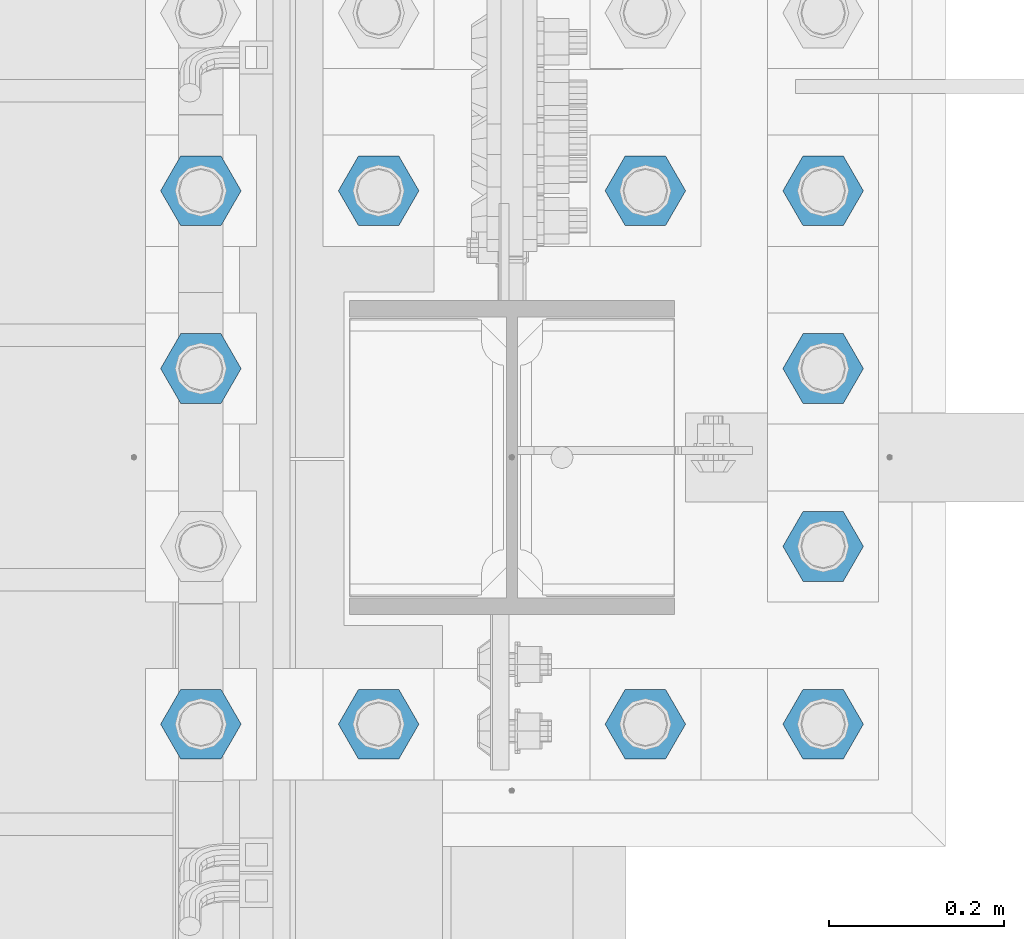
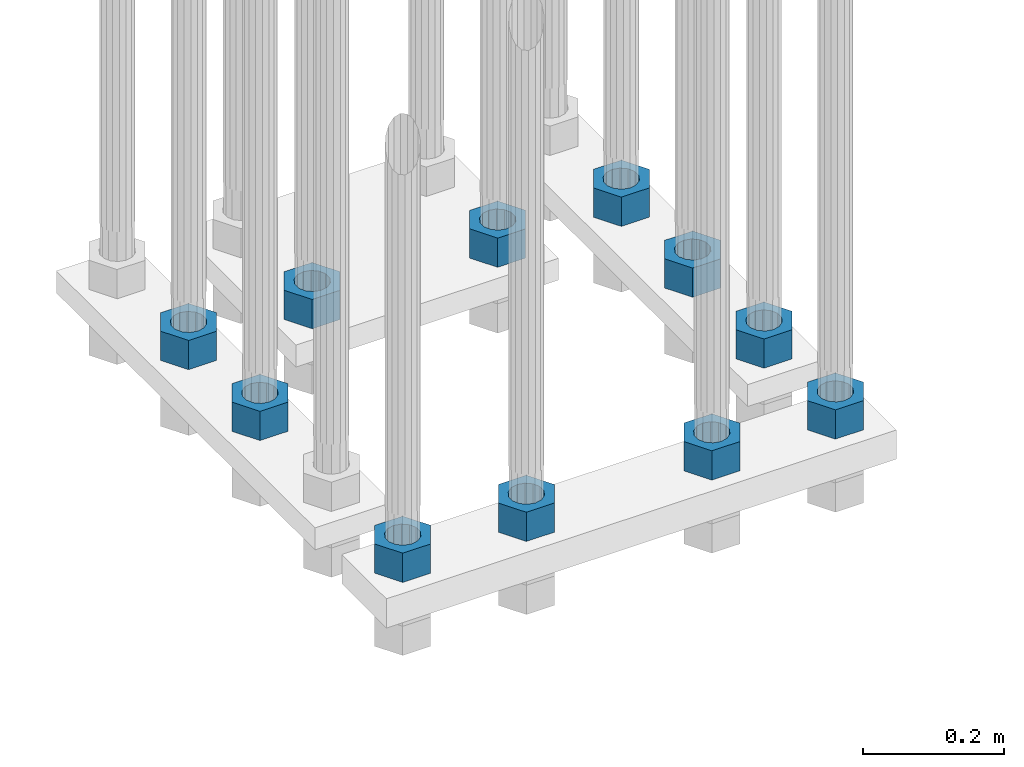
# One storey, part 2089 of 3843: 11 beams, 1 element without a shape of its own.
"""IFC2X3 building model written with IfcOpenShell, lengths in millimetres."""

import ifcopenshell
import ifcopenshell.guid

model = None  # the IFC model being written
_history = None  # IfcOwnerHistory: only IFC2X3 demands one
_inside = {}  # id of a spatial element -> (the spatial element, [elements in it])
_under = {}  # id of a project, library or spatial element -> (it, [spatial elements below it])
_declared = {}  # id of a project -> (the project, [libraries it declares])
_typed = {}  # id of a type object -> (the type object, [elements of that type])
_made_of = {}  # id of a material, layer set ... -> (it, [elements and type objects made of it])


def new_model(schema):
    """Start an empty IFC model of exactly this schema.

    Asked for "IFC4X3", IfcOpenShell would pick the latest addendum, in which some entities
    have other attributes; the version numbers below select the first issue.
    IFC2X3 requires an IfcOwnerHistory on every rooted entity: one is made here for all.
    """
    global model, _history
    if schema == "IFC4X3":
        model = ifcopenshell.file(schema_version=(4, 3, 0, 0))
    else:
        model = ifcopenshell.file(schema=schema)
    _inside.clear()
    _under.clear()
    _declared.clear()
    _typed.clear()
    _made_of.clear()
    _history = None
    if model.schema == "IFC2X3":
        org = make("IfcOrganization", Name="unknown")
        user = make(
            "IfcPersonAndOrganization",
            ThePerson=make("IfcPerson", FamilyName="unknown"),
            TheOrganization=org,
        )
        app = make(
            "IfcApplication",
            ApplicationDeveloper=org,
            Version="unknown",
            ApplicationFullName="unknown",
            ApplicationIdentifier="unknown",
        )
        _history = make(
            "IfcOwnerHistory",
            OwningUser=user,
            OwningApplication=app,
            ChangeAction="ADDED",
            CreationDate=0,
        )
    return model


def make(cls, **values):
    """One entity of the class cls with the attributes given. An attribute that is None is left unset."""
    return model.create_entity(
        cls, **{name: value for name, value in values.items() if value is not None}
    )


def rooted(cls, **values):
    """An entity with a GlobalId (a new one), such as an element, a storey or a relation."""
    return make(cls, GlobalId=ifcopenshell.guid.new(), OwnerHistory=_history, **values)


def si_unit(unit_type, name, prefix=None):
    """IfcSIUnit, for example si_unit("LENGTHUNIT", "METRE", prefix="MILLI")."""
    return make("IfcSIUnit", UnitType=unit_type, Prefix=prefix, Name=name)


def assignment(units):
    """IfcUnitAssignment: the units of a project."""
    return None if units is None else make("IfcUnitAssignment", Units=units)


def point(xyz):
    """IfcCartesianPoint."""
    return None if xyz is None else make("IfcCartesianPoint", Coordinates=xyz)


def direction(xyz):
    """IfcDirection."""
    return None if xyz is None else make("IfcDirection", DirectionRatios=xyz)


def frame(location, z_axis=None, x_axis=None):
    """IfcAxis2Placement3D, a coordinate frame: its origin and axes. An axis left out is left unset."""
    return make(
        "IfcAxis2Placement3D",
        Location=point(location),
        Axis=direction(z_axis),
        RefDirection=direction(x_axis),
    )


def origin_with_axes():
    """The frame at (0, 0, 0) with the z axis (0, 0, 1) and the x axis (1, 0, 0) written out."""
    return frame((0.0, 0.0, 0.0), z_axis=(0.0, 0.0, 1.0), x_axis=(1.0, 0.0, 0.0))


def place(relative_to, where):
    """IfcLocalPlacement: puts the frame where relative to a parent placement (None: the world)."""
    return make(
        "IfcLocalPlacement", PlacementRelTo=relative_to, RelativePlacement=where
    )


def context(
    kind, dimensions, precision=None, world=None, true_north=None, identifier=None
):
    """IfcGeometricRepresentationContext, for example the 3D "Model" context."""
    return make(
        "IfcGeometricRepresentationContext",
        ContextIdentifier=identifier,
        ContextType=kind,
        CoordinateSpaceDimension=dimensions,
        Precision=precision,
        WorldCoordinateSystem=world,
        TrueNorth=true_north,
    )


def subcontext(parent, identifier, kind, view, scale=None):
    """IfcGeometricRepresentationSubContext, for example "Body" below "Model"."""
    return make(
        "IfcGeometricRepresentationSubContext",
        ContextIdentifier=identifier,
        ContextType=kind,
        ParentContext=parent,
        TargetScale=scale,
        TargetView=view,
    )


def project(units=None, contexts=None):
    """IfcProject with its units and contexts."""
    return rooted(
        "IfcProject",
        Name="project",
        RepresentationContexts=contexts,
        UnitsInContext=assignment(units),
    )


def spatial(cls, under=None, at=None, **own):
    """A site, building, storey or space (cls), placed at a placement, below another one or the project."""
    s = rooted(cls, ObjectPlacement=at, **own)
    if under is not None:
        _under.setdefault(under.id(), (under, []))[1].append(s)
    return s


def faces_of(points, faces, orient=None, outer=None):
    """IfcFace entities. A face is a list of loops; a loop is a list of indices into points, from 0.

    orient and outer hold one flag for each loop. By default every Orientation is true, the
    first loop of a face is its IfcFaceOuterBound and the others are IfcFaceBound.
    """
    made = []
    for i, loops in enumerate(faces):
        bounds = []
        for j, loop in enumerate(loops):
            is_outer = j == 0 if outer is None else outer[i][j]
            bounds.append(
                make(
                    "IfcFaceOuterBound" if is_outer else "IfcFaceBound",
                    Bound=make("IfcPolyLoop", Polygon=[points[k] for k in loop]),
                    Orientation=True if orient is None else orient[i][j],
                )
            )
        made.append(make("IfcFace", Bounds=bounds))
    return made


def faceted_brep(points, faces, orient=None, outer=None, voids=None):
    """IfcFacetedBrep: a solid bounded by flat faces; with voids (closed shells), ...WithVoids."""
    shared = [point(p) for p in points]
    hull = make("IfcClosedShell", CfsFaces=faces_of(shared, faces, orient, outer))
    if voids is None:
        return make("IfcFacetedBrep", Outer=hull)
    return make(
        "IfcFacetedBrepWithVoids",
        Outer=hull,
        Voids=[
            make(cls, CfsFaces=faces_of(shared, fs, o, b)) for cls, fs, o, b in voids
        ],
    )


def shape(context_of_items, identifier, shape_type, items):
    """IfcShapeRepresentation: the items that make up one representation, for example the "Body"."""
    return make(
        "IfcShapeRepresentation",
        ContextOfItems=context_of_items,
        RepresentationIdentifier=identifier,
        RepresentationType=shape_type,
        Items=items,
    )


def material(Name=None, Category=None):
    """IfcMaterial."""
    return make("IfcMaterial", Name=Name, Category=Category)


def made_of(thing, what):
    """Note that an element or type object is made of a material, layer set ...; save() writes the relation."""
    if what is not None:
        _made_of.setdefault(what.id(), (what, []))[1].append(thing)
    return thing


def type_object(cls, material=None, **own):
    """A type object (cls), such as IfcWallType, which elements share."""
    return made_of(rooted(cls, **own), material)


def element(
    cls,
    number,
    at=None,
    inside=None,
    cuts=None,
    type_object=None,
    material=None,
    context=None,
    identifier="Body",
    shape_type=None,
    held_by="IfcProductDefinitionShape",
    body=None,
    shapes=None,
    **own,
):
    """One element of the class cls, such as IfcWall. Its Tag is "e" and its number.

    at: its placement. inside: the storey or other place that contains it. cuts: it is an
    opening in that element (IfcRelVoidsElement). A single representation is given by context,
    identifier, shape_type and body (its items); several are given by shapes. held_by: the class
    of the entity that holds the representations. save() writes the other relations.
    """
    e = rooted(cls, Tag="e%d" % number, ObjectPlacement=at, **own)
    if body is not None:
        shapes = [shape(context, identifier, shape_type, body)]
    if shapes is not None:
        e.Representation = make(held_by, Representations=shapes)
    if inside is not None:
        _inside.setdefault(inside.id(), (inside, []))[1].append(e)
    if cuts is not None:
        rooted(
            "IfcRelVoidsElement", RelatingBuildingElement=cuts, RelatedOpeningElement=e
        )
    if type_object is not None:
        _typed.setdefault(type_object.id(), (type_object, []))[1].append(e)
    return made_of(e, material)


def aggregate(whole, parts):
    """IfcRelAggregates: a whole, such as a stair, and the parts it consists of."""
    return rooted("IfcRelAggregates", RelatingObject=whole, RelatedObjects=parts)


def save(model, path):
    """Write the relations noted so far, then the file.

    IfcRelAggregates (storeys below a building ...), IfcRelContainedInSpatialStructure (elements
    in a storey), IfcRelDefinesByType, IfcRelAssociatesMaterial and IfcRelDeclares: one each for
    every whole, place, type object, material and project.
    """
    for whole, parts in _under.values():
        aggregate(whole, parts)
    for where, things in _inside.values():
        rooted(
            "IfcRelContainedInSpatialStructure",
            RelatedElements=things,
            RelatingStructure=where,
        )
    for kind, things in _typed.values():
        rooted("IfcRelDefinesByType", RelatedObjects=things, RelatingType=kind)
    for what, things in _made_of.values():
        rooted("IfcRelAssociatesMaterial", RelatedObjects=things, RelatingMaterial=what)
    for by, libraries in _declared.values():
        rooted("IfcRelDeclares", RelatingContext=by, RelatedDefinitions=libraries)
    model.write(path)


model = new_model("IFC2X3")

# Units and contexts
model_context = context("Model", 3, precision=1e-05, world=origin_with_axes())
body_context = subcontext(model_context, "Body", "Model", "MODEL_VIEW")
ifc_project = project(units=[si_unit("LENGTHUNIT", "METRE", prefix="MILLI"), si_unit("AREAUNIT", "SQUARE_METRE"), si_unit("VOLUMEUNIT", "CUBIC_METRE"), si_unit("MASSUNIT", "GRAM", prefix="KILO"), si_unit("TIMEUNIT", "SECOND"), si_unit("PLANEANGLEUNIT", "RADIAN"), si_unit("SOLIDANGLEUNIT", "STERADIAN"), si_unit("THERMODYNAMICTEMPERATUREUNIT", "DEGREE_CELSIUS"), si_unit("LUMINOUSINTENSITYUNIT", "LUMEN")], contexts=[model_context])

# Site, building, storey
site_placement = place(None, origin_with_axes())
site = spatial("IfcSite", under=ifc_project, at=site_placement, CompositionType="ELEMENT")
building_placement = place(site_placement, origin_with_axes())
building = spatial("IfcBuilding", under=site, at=building_placement, Name="Undefined", CompositionType="ELEMENT")
storey_placement = place(building_placement, origin_with_axes())
storey = spatial("IfcBuildingStorey", under=building, at=storey_placement, Name="Undefined", CompositionType="ELEMENT", Elevation=0.0)

# Assembly, beams
assembly_placement = place(storey_placement, origin_with_axes())
assembly = element("IfcElementAssembly", 1, at=assembly_placement, inside=storey, Name="TEMPLATE", AssemblyPlace="NOTDEFINED", PredefinedType="RIGID_FRAME")
ifc_material = material(Name="STEEL/A572-50")
beam_type = type_object("IfcBeamType", Name="2_HEAVY_HEX_NUT", PredefinedType="NOTDEFINED")
beam_1_placement = place(assembly_placement, frame((55575.2, 20408.9, 28701.9999969482), z_axis=(0.0, -1.0, 0.0), x_axis=(0.0, 0.0, -1.0)))
beam_1 = element("IfcBeam", 2, at=beam_1_placement, type_object=beam_type, material=ifc_material, Name="NUT", ObjectType="2_HEAVY_HEX_NUT", context=body_context, shape_type="Brep", body=[
    faceted_brep([(0.0, -46.0369987487793, 0.0), (0.0, -23.0184993743896, -39.869213104248), (50.7999999999993, -23.0184993743896, -39.869213104248), (50.7999999999993, -46.0369987487793, 0.0), (0.0, 23.0184993743896, -39.869213104248), (50.7999999999993, 23.0184993743896, -39.869213104248), (0.0, 46.0369987487793, 0.0), (50.7999999999993, 46.0369987487793, 0.0), (0.0, 23.0184993743896, 39.869213104248), (50.7999999999993, 23.0184993743896, 39.869213104248), (0.0, -23.0184993743896, 39.869213104248), (50.7999999999993, -23.0184993743896, 39.869213104248), (0.0, 0.0, 26.1940002441406), (0.0, 11.3650617044477, 23.5999013092805), (50.7999999999993, 11.3650617044477, 23.5999013092805), (50.7999999999993, 0.0, 26.1940002441406), (0.0, 20.4791109456419, 16.3316083006721), (50.7999999999993, 20.4791109456419, 16.3316083006721), (0.0, 25.5370200498292, 5.82867859874386), (50.7999999999993, 25.5370200498292, 5.82867859874386), (0.0, 25.5370200498292, -5.82867859874386), (50.7999999999993, 25.5370200498292, -5.82867859874386), (0.0, 20.4791109456419, -16.3316083006721), (50.7999999999993, 20.4791109456419, -16.3316083006721), (0.0, 11.3650617044477, -23.5999013092805), (50.7999999999993, 11.3650617044477, -23.5999013092805), (0.0, 0.0, -26.1940002441406), (50.7999999999993, 0.0, -26.1940002441406), (0.0, -11.3650617044477, -23.5999013092805), (50.7999999999993, -11.3650617044477, -23.5999013092805), (0.0, -20.4791109456419, -16.3316083006721), (50.7999999999993, -20.4791109456419, -16.3316083006721), (0.0, -25.5370200498292, -5.82867859874386), (50.7999999999993, -25.5370200498292, -5.82867859874386), (0.0, -25.5370200498292, 5.82867859874386), (50.7999999999993, -25.5370200498292, 5.82867859874386), (0.0, -20.4791109456419, 16.3316083006721), (50.7999999999993, -20.4791109456419, 16.3316083006721), (0.0, -11.3650617044477, 23.5999013092805), (50.7999999999993, -11.3650617044477, 23.5999013092805)], [[[0, 1, 2, 3]], [[1, 4, 5, 2]], [[4, 6, 7, 5]], [[6, 8, 9, 7]], [[8, 10, 11, 9]], [[10, 0, 3, 11]], [[12, 13, 14, 15]], [[13, 16, 17, 14]], [[16, 18, 19, 17]], [[18, 20, 21, 19]], [[20, 22, 23, 21]], [[22, 24, 25, 23]], [[24, 26, 27, 25]], [[26, 28, 29, 27]], [[28, 30, 31, 29]], [[30, 32, 33, 31]], [[32, 34, 35, 33]], [[34, 36, 37, 35]], [[36, 38, 39, 37]], [[38, 12, 15, 39]], [[5, 7, 9, 11, 3, 2], [17, 19, 21, 23, 25, 27, 29, 31, 33, 35, 37, 39, 15, 14]], [[10, 8, 6, 4, 1, 0], [38, 36, 34, 32, 30, 28, 26, 24, 22, 20, 18, 16, 13, 12]]]),
])
beam_2_placement = place(assembly_placement, frame((55575.2, 20612.1, 28701.9999969482), z_axis=(0.0, -1.0, 0.0), x_axis=(0.0, 0.0, -1.0)))
beam_2 = element("IfcBeam", 3, at=beam_2_placement, type_object=beam_type, material=ifc_material, Name="NUT", ObjectType="2_HEAVY_HEX_NUT", context=body_context, shape_type="Brep", body=[
    faceted_brep([(0.0, -46.0369987487793, 0.0), (0.0, -23.0184993743896, -39.869213104248), (50.7999999999993, -23.0184993743896, -39.869213104248), (50.7999999999993, -46.0369987487793, 0.0), (0.0, 23.0184993743896, -39.869213104248), (50.7999999999993, 23.0184993743896, -39.869213104248), (0.0, 46.0369987487793, 0.0), (50.7999999999993, 46.0369987487793, 0.0), (0.0, 23.0184993743896, 39.869213104248), (50.7999999999993, 23.0184993743896, 39.869213104248), (0.0, -23.0184993743896, 39.869213104248), (50.7999999999993, -23.0184993743896, 39.869213104248), (0.0, 0.0, 26.1940002441406), (0.0, 11.3650617044477, 23.5999013092805), (50.7999999999993, 11.3650617044477, 23.5999013092805), (50.7999999999993, 0.0, 26.1940002441406), (0.0, 20.4791109456419, 16.3316083006721), (50.7999999999993, 20.4791109456419, 16.3316083006721), (0.0, 25.5370200498292, 5.82867859874386), (50.7999999999993, 25.5370200498292, 5.82867859874386), (0.0, 25.5370200498292, -5.82867859874386), (50.7999999999993, 25.5370200498292, -5.82867859874386), (0.0, 20.4791109456419, -16.3316083006721), (50.7999999999993, 20.4791109456419, -16.3316083006721), (0.0, 11.3650617044477, -23.5999013092805), (50.7999999999993, 11.3650617044477, -23.5999013092805), (0.0, 0.0, -26.1940002441406), (50.7999999999993, 0.0, -26.1940002441406), (0.0, -11.3650617044477, -23.5999013092805), (50.7999999999993, -11.3650617044477, -23.5999013092805), (0.0, -20.4791109456419, -16.3316083006721), (50.7999999999993, -20.4791109456419, -16.3316083006721), (0.0, -25.5370200498292, -5.82867859874386), (50.7999999999993, -25.5370200498292, -5.82867859874386), (0.0, -25.5370200498292, 5.82867859874386), (50.7999999999993, -25.5370200498292, 5.82867859874386), (0.0, -20.4791109456419, 16.3316083006721), (50.7999999999993, -20.4791109456419, 16.3316083006721), (0.0, -11.3650617044477, 23.5999013092805), (50.7999999999993, -11.3650617044477, 23.5999013092805)], [[[0, 1, 2, 3]], [[1, 4, 5, 2]], [[4, 6, 7, 5]], [[6, 8, 9, 7]], [[8, 10, 11, 9]], [[10, 0, 3, 11]], [[12, 13, 14, 15]], [[13, 16, 17, 14]], [[16, 18, 19, 17]], [[18, 20, 21, 19]], [[20, 22, 23, 21]], [[22, 24, 25, 23]], [[24, 26, 27, 25]], [[26, 28, 29, 27]], [[28, 30, 31, 29]], [[30, 32, 33, 31]], [[32, 34, 35, 33]], [[34, 36, 37, 35]], [[36, 38, 39, 37]], [[38, 12, 15, 39]], [[5, 7, 9, 11, 3, 2], [17, 19, 21, 23, 25, 27, 29, 31, 33, 35, 37, 39, 15, 14]], [[10, 8, 6, 4, 1, 0], [38, 36, 34, 32, 30, 28, 26, 24, 22, 20, 18, 16, 13, 12]]]),
])
beam_3_placement = place(assembly_placement, frame((55778.4, 20612.1, 28701.9999969482), z_axis=(0.0, -1.0, 0.0), x_axis=(0.0, 0.0, -1.0)))
beam_3 = element("IfcBeam", 4, at=beam_3_placement, type_object=beam_type, material=ifc_material, Name="NUT", ObjectType="2_HEAVY_HEX_NUT", context=body_context, shape_type="Brep", body=[
    faceted_brep([(0.0, -46.0369987487793, 0.0), (0.0, -23.0184993743896, -39.869213104248), (50.7999999999993, -23.0184993743896, -39.869213104248), (50.7999999999993, -46.0369987487793, 0.0), (0.0, 23.0184993743896, -39.869213104248), (50.7999999999993, 23.0184993743896, -39.869213104248), (0.0, 46.0369987487793, 0.0), (50.7999999999993, 46.0369987487793, 0.0), (0.0, 23.0184993743896, 39.869213104248), (50.7999999999993, 23.0184993743896, 39.869213104248), (0.0, -23.0184993743896, 39.869213104248), (50.7999999999993, -23.0184993743896, 39.869213104248), (0.0, 0.0, 26.1940002441406), (0.0, 11.3650617044477, 23.5999013092805), (50.7999999999993, 11.3650617044477, 23.5999013092805), (50.7999999999993, 0.0, 26.1940002441406), (0.0, 20.4791109456419, 16.3316083006721), (50.7999999999993, 20.4791109456419, 16.3316083006721), (0.0, 25.5370200498292, 5.82867859874386), (50.7999999999993, 25.5370200498292, 5.82867859874386), (0.0, 25.5370200498292, -5.82867859874386), (50.7999999999993, 25.5370200498292, -5.82867859874386), (0.0, 20.4791109456419, -16.3316083006721), (50.7999999999993, 20.4791109456419, -16.3316083006721), (0.0, 11.3650617044477, -23.5999013092805), (50.7999999999993, 11.3650617044477, -23.5999013092805), (0.0, 0.0, -26.1940002441406), (50.7999999999993, 0.0, -26.1940002441406), (0.0, -11.3650617044477, -23.5999013092805), (50.7999999999993, -11.3650617044477, -23.5999013092805), (0.0, -20.4791109456419, -16.3316083006721), (50.7999999999993, -20.4791109456419, -16.3316083006721), (0.0, -25.5370200498292, -5.82867859874386), (50.7999999999993, -25.5370200498292, -5.82867859874386), (0.0, -25.5370200498292, 5.82867859874386), (50.7999999999993, -25.5370200498292, 5.82867859874386), (0.0, -20.4791109456419, 16.3316083006721), (50.7999999999993, -20.4791109456419, 16.3316083006721), (0.0, -11.3650617044477, 23.5999013092805), (50.7999999999993, -11.3650617044477, 23.5999013092805)], [[[0, 1, 2, 3]], [[1, 4, 5, 2]], [[4, 6, 7, 5]], [[6, 8, 9, 7]], [[8, 10, 11, 9]], [[10, 0, 3, 11]], [[12, 13, 14, 15]], [[13, 16, 17, 14]], [[16, 18, 19, 17]], [[18, 20, 21, 19]], [[20, 22, 23, 21]], [[22, 24, 25, 23]], [[24, 26, 27, 25]], [[26, 28, 29, 27]], [[28, 30, 31, 29]], [[30, 32, 33, 31]], [[32, 34, 35, 33]], [[34, 36, 37, 35]], [[36, 38, 39, 37]], [[38, 12, 15, 39]], [[5, 7, 9, 11, 3, 2], [17, 19, 21, 23, 25, 27, 29, 31, 33, 35, 37, 39, 15, 14]], [[10, 8, 6, 4, 1, 0], [38, 36, 34, 32, 30, 28, 26, 24, 22, 20, 18, 16, 13, 12]]]),
])
beam_4_placement = place(assembly_placement, frame((56083.2, 20612.1, 28701.9999969482), z_axis=(0.0, 1.0, 0.0), x_axis=(0.0, 0.0, -1.0)))
beam_4 = element("IfcBeam", 5, at=beam_4_placement, type_object=beam_type, material=ifc_material, Name="NUT", ObjectType="2_HEAVY_HEX_NUT", context=body_context, shape_type="Brep", body=[
    faceted_brep([(0.0, -46.0369987487793, 0.0), (0.0, -23.0184993743896, -39.869213104248), (50.7999999999993, -23.0184993743896, -39.869213104248), (50.7999999999993, -46.0369987487793, 0.0), (0.0, 23.0184993743896, -39.869213104248), (50.7999999999993, 23.0184993743896, -39.869213104248), (0.0, 46.0369987487793, 0.0), (50.7999999999993, 46.0369987487793, 0.0), (0.0, 23.0184993743896, 39.869213104248), (50.7999999999993, 23.0184993743896, 39.869213104248), (0.0, -23.0184993743896, 39.869213104248), (50.7999999999993, -23.0184993743896, 39.869213104248), (0.0, 0.0, 26.1940002441406), (0.0, 11.3650617044477, 23.5999013092805), (50.7999999999993, 11.3650617044477, 23.5999013092805), (50.7999999999993, 0.0, 26.1940002441406), (0.0, 20.4791109456419, 16.3316083006721), (50.7999999999993, 20.4791109456419, 16.3316083006721), (0.0, 25.5370200498292, 5.82867859874386), (50.7999999999993, 25.5370200498292, 5.82867859874386), (0.0, 25.5370200498292, -5.82867859874386), (50.7999999999993, 25.5370200498292, -5.82867859874386), (0.0, 20.4791109456419, -16.3316083006721), (50.7999999999993, 20.4791109456419, -16.3316083006721), (0.0, 11.3650617044477, -23.5999013092805), (50.7999999999993, 11.3650617044477, -23.5999013092805), (0.0, 0.0, -26.1940002441406), (50.7999999999993, 0.0, -26.1940002441406), (0.0, -11.3650617044477, -23.5999013092805), (50.7999999999993, -11.3650617044477, -23.5999013092805), (0.0, -20.4791109456419, -16.3316083006721), (50.7999999999993, -20.4791109456419, -16.3316083006721), (0.0, -25.5370200498292, -5.82867859874386), (50.7999999999993, -25.5370200498292, -5.82867859874386), (0.0, -25.5370200498292, 5.82867859874386), (50.7999999999993, -25.5370200498292, 5.82867859874386), (0.0, -20.4791109456419, 16.3316083006721), (50.7999999999993, -20.4791109456419, 16.3316083006721), (0.0, -11.3650617044477, 23.5999013092805), (50.7999999999993, -11.3650617044477, 23.5999013092805)], [[[0, 1, 2, 3]], [[1, 4, 5, 2]], [[4, 6, 7, 5]], [[6, 8, 9, 7]], [[8, 10, 11, 9]], [[10, 0, 3, 11]], [[12, 13, 14, 15]], [[13, 16, 17, 14]], [[16, 18, 19, 17]], [[18, 20, 21, 19]], [[20, 22, 23, 21]], [[22, 24, 25, 23]], [[24, 26, 27, 25]], [[26, 28, 29, 27]], [[28, 30, 31, 29]], [[30, 32, 33, 31]], [[32, 34, 35, 33]], [[34, 36, 37, 35]], [[36, 38, 39, 37]], [[38, 12, 15, 39]], [[5, 7, 9, 11, 3, 2], [17, 19, 21, 23, 25, 27, 29, 31, 33, 35, 37, 39, 15, 14]], [[10, 8, 6, 4, 1, 0], [38, 36, 34, 32, 30, 28, 26, 24, 22, 20, 18, 16, 13, 12]]]),
])
beam_5_placement = place(assembly_placement, frame((56286.4, 20612.1, 28701.9999969482), z_axis=(0.0, 1.0, 0.0), x_axis=(0.0, 0.0, -1.0)))
beam_5 = element("IfcBeam", 6, at=beam_5_placement, type_object=beam_type, material=ifc_material, Name="NUT", ObjectType="2_HEAVY_HEX_NUT", context=body_context, shape_type="Brep", body=[
    faceted_brep([(0.0, -46.0369987487793, 0.0), (0.0, -23.0184993743896, -39.869213104248), (50.7999999999993, -23.0184993743896, -39.869213104248), (50.7999999999993, -46.0369987487793, 0.0), (0.0, 23.0184993743896, -39.869213104248), (50.7999999999993, 23.0184993743896, -39.869213104248), (0.0, 46.0369987487793, 0.0), (50.7999999999993, 46.0369987487793, 0.0), (0.0, 23.0184993743896, 39.869213104248), (50.7999999999993, 23.0184993743896, 39.869213104248), (0.0, -23.0184993743896, 39.869213104248), (50.7999999999993, -23.0184993743896, 39.869213104248), (0.0, 0.0, 26.1940002441406), (0.0, 11.3650617044477, 23.5999013092805), (50.7999999999993, 11.3650617044477, 23.5999013092805), (50.7999999999993, 0.0, 26.1940002441406), (0.0, 20.4791109456419, 16.3316083006721), (50.7999999999993, 20.4791109456419, 16.3316083006721), (0.0, 25.5370200498292, 5.82867859874386), (50.7999999999993, 25.5370200498292, 5.82867859874386), (0.0, 25.5370200498292, -5.82867859874386), (50.7999999999993, 25.5370200498292, -5.82867859874386), (0.0, 20.4791109456419, -16.3316083006721), (50.7999999999993, 20.4791109456419, -16.3316083006721), (0.0, 11.3650617044477, -23.5999013092805), (50.7999999999993, 11.3650617044477, -23.5999013092805), (0.0, 0.0, -26.1940002441406), (50.7999999999993, 0.0, -26.1940002441406), (0.0, -11.3650617044477, -23.5999013092805), (50.7999999999993, -11.3650617044477, -23.5999013092805), (0.0, -20.4791109456419, -16.3316083006721), (50.7999999999993, -20.4791109456419, -16.3316083006721), (0.0, -25.5370200498292, -5.82867859874386), (50.7999999999993, -25.5370200498292, -5.82867859874386), (0.0, -25.5370200498292, 5.82867859874386), (50.7999999999993, -25.5370200498292, 5.82867859874386), (0.0, -20.4791109456419, 16.3316083006721), (50.7999999999993, -20.4791109456419, 16.3316083006721), (0.0, -11.3650617044477, 23.5999013092805), (50.7999999999993, -11.3650617044477, 23.5999013092805)], [[[0, 1, 2, 3]], [[1, 4, 5, 2]], [[4, 6, 7, 5]], [[6, 8, 9, 7]], [[8, 10, 11, 9]], [[10, 0, 3, 11]], [[12, 13, 14, 15]], [[13, 16, 17, 14]], [[16, 18, 19, 17]], [[18, 20, 21, 19]], [[20, 22, 23, 21]], [[22, 24, 25, 23]], [[24, 26, 27, 25]], [[26, 28, 29, 27]], [[28, 30, 31, 29]], [[30, 32, 33, 31]], [[32, 34, 35, 33]], [[34, 36, 37, 35]], [[36, 38, 39, 37]], [[38, 12, 15, 39]], [[5, 7, 9, 11, 3, 2], [17, 19, 21, 23, 25, 27, 29, 31, 33, 35, 37, 39, 15, 14]], [[10, 8, 6, 4, 1, 0], [38, 36, 34, 32, 30, 28, 26, 24, 22, 20, 18, 16, 13, 12]]]),
])
beam_6_placement = place(assembly_placement, frame((56286.4, 20408.9, 28701.9999969482), z_axis=(0.0, 1.0, 0.0), x_axis=(0.0, 0.0, -1.0)))
beam_6 = element("IfcBeam", 7, at=beam_6_placement, type_object=beam_type, material=ifc_material, Name="NUT", ObjectType="2_HEAVY_HEX_NUT", context=body_context, shape_type="Brep", body=[
    faceted_brep([(0.0, -46.0369987487793, 0.0), (0.0, -23.0184993743896, -39.869213104248), (50.7999999999993, -23.0184993743896, -39.869213104248), (50.7999999999993, -46.0369987487793, 0.0), (0.0, 23.0184993743896, -39.869213104248), (50.7999999999993, 23.0184993743896, -39.869213104248), (0.0, 46.0369987487793, 0.0), (50.7999999999993, 46.0369987487793, 0.0), (0.0, 23.0184993743896, 39.869213104248), (50.7999999999993, 23.0184993743896, 39.869213104248), (0.0, -23.0184993743896, 39.869213104248), (50.7999999999993, -23.0184993743896, 39.869213104248), (0.0, 0.0, 26.1940002441406), (0.0, 11.3650617044477, 23.5999013092805), (50.7999999999993, 11.3650617044477, 23.5999013092805), (50.7999999999993, 0.0, 26.1940002441406), (0.0, 20.4791109456419, 16.3316083006721), (50.7999999999993, 20.4791109456419, 16.3316083006721), (0.0, 25.5370200498292, 5.82867859874386), (50.7999999999993, 25.5370200498292, 5.82867859874386), (0.0, 25.5370200498292, -5.82867859874386), (50.7999999999993, 25.5370200498292, -5.82867859874386), (0.0, 20.4791109456419, -16.3316083006721), (50.7999999999993, 20.4791109456419, -16.3316083006721), (0.0, 11.3650617044477, -23.5999013092805), (50.7999999999993, 11.3650617044477, -23.5999013092805), (0.0, 0.0, -26.1940002441406), (50.7999999999993, 0.0, -26.1940002441406), (0.0, -11.3650617044477, -23.5999013092805), (50.7999999999993, -11.3650617044477, -23.5999013092805), (0.0, -20.4791109456419, -16.3316083006721), (50.7999999999993, -20.4791109456419, -16.3316083006721), (0.0, -25.5370200498292, -5.82867859874386), (50.7999999999993, -25.5370200498292, -5.82867859874386), (0.0, -25.5370200498292, 5.82867859874386), (50.7999999999993, -25.5370200498292, 5.82867859874386), (0.0, -20.4791109456419, 16.3316083006721), (50.7999999999993, -20.4791109456419, 16.3316083006721), (0.0, -11.3650617044477, 23.5999013092805), (50.7999999999993, -11.3650617044477, 23.5999013092805)], [[[0, 1, 2, 3]], [[1, 4, 5, 2]], [[4, 6, 7, 5]], [[6, 8, 9, 7]], [[8, 10, 11, 9]], [[10, 0, 3, 11]], [[12, 13, 14, 15]], [[13, 16, 17, 14]], [[16, 18, 19, 17]], [[18, 20, 21, 19]], [[20, 22, 23, 21]], [[22, 24, 25, 23]], [[24, 26, 27, 25]], [[26, 28, 29, 27]], [[28, 30, 31, 29]], [[30, 32, 33, 31]], [[32, 34, 35, 33]], [[34, 36, 37, 35]], [[36, 38, 39, 37]], [[38, 12, 15, 39]], [[5, 7, 9, 11, 3, 2], [17, 19, 21, 23, 25, 27, 29, 31, 33, 35, 37, 39, 15, 14]], [[10, 8, 6, 4, 1, 0], [38, 36, 34, 32, 30, 28, 26, 24, 22, 20, 18, 16, 13, 12]]]),
])
beam_7_placement = place(assembly_placement, frame((56286.4, 20205.7, 28701.9999969482), z_axis=(0.0, 1.0, 0.0), x_axis=(0.0, 0.0, -1.0)))
beam_7 = element("IfcBeam", 8, at=beam_7_placement, type_object=beam_type, material=ifc_material, Name="NUT", ObjectType="2_HEAVY_HEX_NUT", context=body_context, shape_type="Brep", body=[
    faceted_brep([(0.0, -46.0369987487793, 0.0), (0.0, -23.0184993743896, -39.869213104248), (50.7999999999993, -23.0184993743896, -39.869213104248), (50.7999999999993, -46.0369987487793, 0.0), (0.0, 23.0184993743896, -39.869213104248), (50.7999999999993, 23.0184993743896, -39.869213104248), (0.0, 46.0369987487793, 0.0), (50.7999999999993, 46.0369987487793, 0.0), (0.0, 23.0184993743896, 39.869213104248), (50.7999999999993, 23.0184993743896, 39.869213104248), (0.0, -23.0184993743896, 39.869213104248), (50.7999999999993, -23.0184993743896, 39.869213104248), (0.0, 0.0, 26.1940002441406), (0.0, 11.3650617044477, 23.5999013092805), (50.7999999999993, 11.3650617044477, 23.5999013092805), (50.7999999999993, 0.0, 26.1940002441406), (0.0, 20.4791109456419, 16.3316083006721), (50.7999999999993, 20.4791109456419, 16.3316083006721), (0.0, 25.5370200498292, 5.82867859874386), (50.7999999999993, 25.5370200498292, 5.82867859874386), (0.0, 25.5370200498292, -5.82867859874386), (50.7999999999993, 25.5370200498292, -5.82867859874386), (0.0, 20.4791109456419, -16.3316083006721), (50.7999999999993, 20.4791109456419, -16.3316083006721), (0.0, 11.3650617044477, -23.5999013092805), (50.7999999999993, 11.3650617044477, -23.5999013092805), (0.0, 0.0, -26.1940002441406), (50.7999999999993, 0.0, -26.1940002441406), (0.0, -11.3650617044477, -23.5999013092805), (50.7999999999993, -11.3650617044477, -23.5999013092805), (0.0, -20.4791109456419, -16.3316083006721), (50.7999999999993, -20.4791109456419, -16.3316083006721), (0.0, -25.5370200498292, -5.82867859874386), (50.7999999999993, -25.5370200498292, -5.82867859874386), (0.0, -25.5370200498292, 5.82867859874386), (50.7999999999993, -25.5370200498292, 5.82867859874386), (0.0, -20.4791109456419, 16.3316083006721), (50.7999999999993, -20.4791109456419, 16.3316083006721), (0.0, -11.3650617044477, 23.5999013092805), (50.7999999999993, -11.3650617044477, 23.5999013092805)], [[[0, 1, 2, 3]], [[1, 4, 5, 2]], [[4, 6, 7, 5]], [[6, 8, 9, 7]], [[8, 10, 11, 9]], [[10, 0, 3, 11]], [[12, 13, 14, 15]], [[13, 16, 17, 14]], [[16, 18, 19, 17]], [[18, 20, 21, 19]], [[20, 22, 23, 21]], [[22, 24, 25, 23]], [[24, 26, 27, 25]], [[26, 28, 29, 27]], [[28, 30, 31, 29]], [[30, 32, 33, 31]], [[32, 34, 35, 33]], [[34, 36, 37, 35]], [[36, 38, 39, 37]], [[38, 12, 15, 39]], [[5, 7, 9, 11, 3, 2], [17, 19, 21, 23, 25, 27, 29, 31, 33, 35, 37, 39, 15, 14]], [[10, 8, 6, 4, 1, 0], [38, 36, 34, 32, 30, 28, 26, 24, 22, 20, 18, 16, 13, 12]]]),
])
beam_8_placement = place(assembly_placement, frame((55575.1999999999, 20002.5, 28701.9999969482), z_axis=(0.0, -1.0, 0.0), x_axis=(0.0, 0.0, -1.0)))
beam_8 = element("IfcBeam", 9, at=beam_8_placement, type_object=beam_type, material=ifc_material, Name="NUT", ObjectType="2_HEAVY_HEX_NUT", context=body_context, shape_type="Brep", body=[
    faceted_brep([(0.0, -46.0369987487793, 0.0), (0.0, -23.0184993743896, -39.869213104248), (50.7999999999993, -23.0184993743896, -39.869213104248), (50.7999999999993, -46.0369987487793, 0.0), (0.0, 23.0184993743896, -39.869213104248), (50.7999999999993, 23.0184993743896, -39.869213104248), (0.0, 46.0369987487793, 0.0), (50.7999999999993, 46.0369987487793, 0.0), (0.0, 23.0184993743896, 39.869213104248), (50.7999999999993, 23.0184993743896, 39.869213104248), (0.0, -23.0184993743896, 39.869213104248), (50.7999999999993, -23.0184993743896, 39.869213104248), (0.0, 0.0, 26.1940002441406), (0.0, 11.3650617044477, 23.5999013092805), (50.7999999999993, 11.3650617044477, 23.5999013092805), (50.7999999999993, 0.0, 26.1940002441406), (0.0, 20.4791109456419, 16.3316083006721), (50.7999999999993, 20.4791109456419, 16.3316083006721), (0.0, 25.5370200498292, 5.82867859874386), (50.7999999999993, 25.5370200498292, 5.82867859874386), (0.0, 25.5370200498292, -5.82867859874386), (50.7999999999993, 25.5370200498292, -5.82867859874386), (0.0, 20.4791109456419, -16.3316083006721), (50.7999999999993, 20.4791109456419, -16.3316083006721), (0.0, 11.3650617044477, -23.5999013092805), (50.7999999999993, 11.3650617044477, -23.5999013092805), (0.0, 0.0, -26.1940002441406), (50.7999999999993, 0.0, -26.1940002441406), (0.0, -11.3650617044477, -23.5999013092805), (50.7999999999993, -11.3650617044477, -23.5999013092805), (0.0, -20.4791109456419, -16.3316083006721), (50.7999999999993, -20.4791109456419, -16.3316083006721), (0.0, -25.5370200498292, -5.82867859874386), (50.7999999999993, -25.5370200498292, -5.82867859874386), (0.0, -25.5370200498292, 5.82867859874386), (50.7999999999993, -25.5370200498292, 5.82867859874386), (0.0, -20.4791109456419, 16.3316083006721), (50.7999999999993, -20.4791109456419, 16.3316083006721), (0.0, -11.3650617044477, 23.5999013092805), (50.7999999999993, -11.3650617044477, 23.5999013092805)], [[[0, 1, 2, 3]], [[1, 4, 5, 2]], [[4, 6, 7, 5]], [[6, 8, 9, 7]], [[8, 10, 11, 9]], [[10, 0, 3, 11]], [[12, 13, 14, 15]], [[13, 16, 17, 14]], [[16, 18, 19, 17]], [[18, 20, 21, 19]], [[20, 22, 23, 21]], [[22, 24, 25, 23]], [[24, 26, 27, 25]], [[26, 28, 29, 27]], [[28, 30, 31, 29]], [[30, 32, 33, 31]], [[32, 34, 35, 33]], [[34, 36, 37, 35]], [[36, 38, 39, 37]], [[38, 12, 15, 39]], [[5, 7, 9, 11, 3, 2], [17, 19, 21, 23, 25, 27, 29, 31, 33, 35, 37, 39, 15, 14]], [[10, 8, 6, 4, 1, 0], [38, 36, 34, 32, 30, 28, 26, 24, 22, 20, 18, 16, 13, 12]]]),
])
beam_9_placement = place(assembly_placement, frame((55778.3999999999, 20002.5, 28701.9999969482), z_axis=(0.0, -1.0, 0.0), x_axis=(0.0, 0.0, -1.0)))
beam_9 = element("IfcBeam", 10, at=beam_9_placement, type_object=beam_type, material=ifc_material, Name="NUT", ObjectType="2_HEAVY_HEX_NUT", context=body_context, shape_type="Brep", body=[
    faceted_brep([(0.0, -46.0369987487793, 0.0), (0.0, -23.0184993743896, -39.869213104248), (50.7999999999993, -23.0184993743896, -39.869213104248), (50.7999999999993, -46.0369987487793, 0.0), (0.0, 23.0184993743896, -39.869213104248), (50.7999999999993, 23.0184993743896, -39.869213104248), (0.0, 46.0369987487793, 0.0), (50.7999999999993, 46.0369987487793, 0.0), (0.0, 23.0184993743896, 39.869213104248), (50.7999999999993, 23.0184993743896, 39.869213104248), (0.0, -23.0184993743896, 39.869213104248), (50.7999999999993, -23.0184993743896, 39.869213104248), (0.0, 0.0, 26.1940002441406), (0.0, 11.3650617044477, 23.5999013092805), (50.7999999999993, 11.3650617044477, 23.5999013092805), (50.7999999999993, 0.0, 26.1940002441406), (0.0, 20.4791109456419, 16.3316083006721), (50.7999999999993, 20.4791109456419, 16.3316083006721), (0.0, 25.5370200498292, 5.82867859874386), (50.7999999999993, 25.5370200498292, 5.82867859874386), (0.0, 25.5370200498292, -5.82867859874386), (50.7999999999993, 25.5370200498292, -5.82867859874386), (0.0, 20.4791109456419, -16.3316083006721), (50.7999999999993, 20.4791109456419, -16.3316083006721), (0.0, 11.3650617044477, -23.5999013092805), (50.7999999999993, 11.3650617044477, -23.5999013092805), (0.0, 0.0, -26.1940002441406), (50.7999999999993, 0.0, -26.1940002441406), (0.0, -11.3650617044477, -23.5999013092805), (50.7999999999993, -11.3650617044477, -23.5999013092805), (0.0, -20.4791109456419, -16.3316083006721), (50.7999999999993, -20.4791109456419, -16.3316083006721), (0.0, -25.5370200498292, -5.82867859874386), (50.7999999999993, -25.5370200498292, -5.82867859874386), (0.0, -25.5370200498292, 5.82867859874386), (50.7999999999993, -25.5370200498292, 5.82867859874386), (0.0, -20.4791109456419, 16.3316083006721), (50.7999999999993, -20.4791109456419, 16.3316083006721), (0.0, -11.3650617044477, 23.5999013092805), (50.7999999999993, -11.3650617044477, 23.5999013092805)], [[[0, 1, 2, 3]], [[1, 4, 5, 2]], [[4, 6, 7, 5]], [[6, 8, 9, 7]], [[8, 10, 11, 9]], [[10, 0, 3, 11]], [[12, 13, 14, 15]], [[13, 16, 17, 14]], [[16, 18, 19, 17]], [[18, 20, 21, 19]], [[20, 22, 23, 21]], [[22, 24, 25, 23]], [[24, 26, 27, 25]], [[26, 28, 29, 27]], [[28, 30, 31, 29]], [[30, 32, 33, 31]], [[32, 34, 35, 33]], [[34, 36, 37, 35]], [[36, 38, 39, 37]], [[38, 12, 15, 39]], [[5, 7, 9, 11, 3, 2], [17, 19, 21, 23, 25, 27, 29, 31, 33, 35, 37, 39, 15, 14]], [[10, 8, 6, 4, 1, 0], [38, 36, 34, 32, 30, 28, 26, 24, 22, 20, 18, 16, 13, 12]]]),
])
beam_10_placement = place(assembly_placement, frame((56083.2, 20002.5, 28701.9999969482), z_axis=(0.0, 1.0, 0.0), x_axis=(0.0, 0.0, -1.0)))
beam_10 = element("IfcBeam", 11, at=beam_10_placement, type_object=beam_type, material=ifc_material, Name="NUT", ObjectType="2_HEAVY_HEX_NUT", context=body_context, shape_type="Brep", body=[
    faceted_brep([(0.0, -46.0369987487793, 0.0), (0.0, -23.0184993743896, -39.869213104248), (50.7999999999993, -23.0184993743896, -39.869213104248), (50.7999999999993, -46.0369987487793, 0.0), (0.0, 23.0184993743896, -39.869213104248), (50.7999999999993, 23.0184993743896, -39.869213104248), (0.0, 46.0369987487793, 0.0), (50.7999999999993, 46.0369987487793, 0.0), (0.0, 23.0184993743896, 39.869213104248), (50.7999999999993, 23.0184993743896, 39.869213104248), (0.0, -23.0184993743896, 39.869213104248), (50.7999999999993, -23.0184993743896, 39.869213104248), (0.0, 0.0, 26.1940002441406), (0.0, 11.3650617044477, 23.5999013092805), (50.7999999999993, 11.3650617044477, 23.5999013092805), (50.7999999999993, 0.0, 26.1940002441406), (0.0, 20.4791109456419, 16.3316083006721), (50.7999999999993, 20.4791109456419, 16.3316083006721), (0.0, 25.5370200498292, 5.82867859874386), (50.7999999999993, 25.5370200498292, 5.82867859874386), (0.0, 25.5370200498292, -5.82867859874386), (50.7999999999993, 25.5370200498292, -5.82867859874386), (0.0, 20.4791109456419, -16.3316083006721), (50.7999999999993, 20.4791109456419, -16.3316083006721), (0.0, 11.3650617044477, -23.5999013092805), (50.7999999999993, 11.3650617044477, -23.5999013092805), (0.0, 0.0, -26.1940002441406), (50.7999999999993, 0.0, -26.1940002441406), (0.0, -11.3650617044477, -23.5999013092805), (50.7999999999993, -11.3650617044477, -23.5999013092805), (0.0, -20.4791109456419, -16.3316083006721), (50.7999999999993, -20.4791109456419, -16.3316083006721), (0.0, -25.5370200498292, -5.82867859874386), (50.7999999999993, -25.5370200498292, -5.82867859874386), (0.0, -25.5370200498292, 5.82867859874386), (50.7999999999993, -25.5370200498292, 5.82867859874386), (0.0, -20.4791109456419, 16.3316083006721), (50.7999999999993, -20.4791109456419, 16.3316083006721), (0.0, -11.3650617044477, 23.5999013092805), (50.7999999999993, -11.3650617044477, 23.5999013092805)], [[[0, 1, 2, 3]], [[1, 4, 5, 2]], [[4, 6, 7, 5]], [[6, 8, 9, 7]], [[8, 10, 11, 9]], [[10, 0, 3, 11]], [[12, 13, 14, 15]], [[13, 16, 17, 14]], [[16, 18, 19, 17]], [[18, 20, 21, 19]], [[20, 22, 23, 21]], [[22, 24, 25, 23]], [[24, 26, 27, 25]], [[26, 28, 29, 27]], [[28, 30, 31, 29]], [[30, 32, 33, 31]], [[32, 34, 35, 33]], [[34, 36, 37, 35]], [[36, 38, 39, 37]], [[38, 12, 15, 39]], [[5, 7, 9, 11, 3, 2], [17, 19, 21, 23, 25, 27, 29, 31, 33, 35, 37, 39, 15, 14]], [[10, 8, 6, 4, 1, 0], [38, 36, 34, 32, 30, 28, 26, 24, 22, 20, 18, 16, 13, 12]]]),
])
beam_11_placement = place(assembly_placement, frame((56286.4, 20002.5, 28701.9999969482), z_axis=(0.0, 1.0, 0.0), x_axis=(0.0, 0.0, -1.0)))
beam_11 = element("IfcBeam", 12, at=beam_11_placement, type_object=beam_type, material=ifc_material, Name="NUT", ObjectType="2_HEAVY_HEX_NUT", context=body_context, shape_type="Brep", body=[
    faceted_brep([(0.0, -46.0369987487793, 0.0), (0.0, -23.0184993743896, -39.869213104248), (50.7999999999993, -23.0184993743896, -39.869213104248), (50.7999999999993, -46.0369987487793, 0.0), (0.0, 23.0184993743896, -39.869213104248), (50.7999999999993, 23.0184993743896, -39.869213104248), (0.0, 46.0369987487793, 0.0), (50.7999999999993, 46.0369987487793, 0.0), (0.0, 23.0184993743896, 39.869213104248), (50.7999999999993, 23.0184993743896, 39.869213104248), (0.0, -23.0184993743896, 39.869213104248), (50.7999999999993, -23.0184993743896, 39.869213104248), (0.0, 0.0, 26.1940002441406), (0.0, 11.3650617044477, 23.5999013092805), (50.7999999999993, 11.3650617044477, 23.5999013092805), (50.7999999999993, 0.0, 26.1940002441406), (0.0, 20.4791109456419, 16.3316083006721), (50.7999999999993, 20.4791109456419, 16.3316083006721), (0.0, 25.5370200498292, 5.82867859874386), (50.7999999999993, 25.5370200498292, 5.82867859874386), (0.0, 25.5370200498292, -5.82867859874386), (50.7999999999993, 25.5370200498292, -5.82867859874386), (0.0, 20.4791109456419, -16.3316083006721), (50.7999999999993, 20.4791109456419, -16.3316083006721), (0.0, 11.3650617044477, -23.5999013092805), (50.7999999999993, 11.3650617044477, -23.5999013092805), (0.0, 0.0, -26.1940002441406), (50.7999999999993, 0.0, -26.1940002441406), (0.0, -11.3650617044477, -23.5999013092805), (50.7999999999993, -11.3650617044477, -23.5999013092805), (0.0, -20.4791109456419, -16.3316083006721), (50.7999999999993, -20.4791109456419, -16.3316083006721), (0.0, -25.5370200498292, -5.82867859874386), (50.7999999999993, -25.5370200498292, -5.82867859874386), (0.0, -25.5370200498292, 5.82867859874386), (50.7999999999993, -25.5370200498292, 5.82867859874386), (0.0, -20.4791109456419, 16.3316083006721), (50.7999999999993, -20.4791109456419, 16.3316083006721), (0.0, -11.3650617044477, 23.5999013092805), (50.7999999999993, -11.3650617044477, 23.5999013092805)], [[[0, 1, 2, 3]], [[1, 4, 5, 2]], [[4, 6, 7, 5]], [[6, 8, 9, 7]], [[8, 10, 11, 9]], [[10, 0, 3, 11]], [[12, 13, 14, 15]], [[13, 16, 17, 14]], [[16, 18, 19, 17]], [[18, 20, 21, 19]], [[20, 22, 23, 21]], [[22, 24, 25, 23]], [[24, 26, 27, 25]], [[26, 28, 29, 27]], [[28, 30, 31, 29]], [[30, 32, 33, 31]], [[32, 34, 35, 33]], [[34, 36, 37, 35]], [[36, 38, 39, 37]], [[38, 12, 15, 39]], [[5, 7, 9, 11, 3, 2], [17, 19, 21, 23, 25, 27, 29, 31, 33, 35, 37, 39, 15, 14]], [[10, 8, 6, 4, 1, 0], [38, 36, 34, 32, 30, 28, 26, 24, 22, 20, 18, 16, 13, 12]]]),
])
aggregate(assembly, [beam_1, beam_2, beam_3, beam_4, beam_5, beam_6, beam_7, beam_8, beam_9, beam_10, beam_11])

save(model, "model.ifc")
